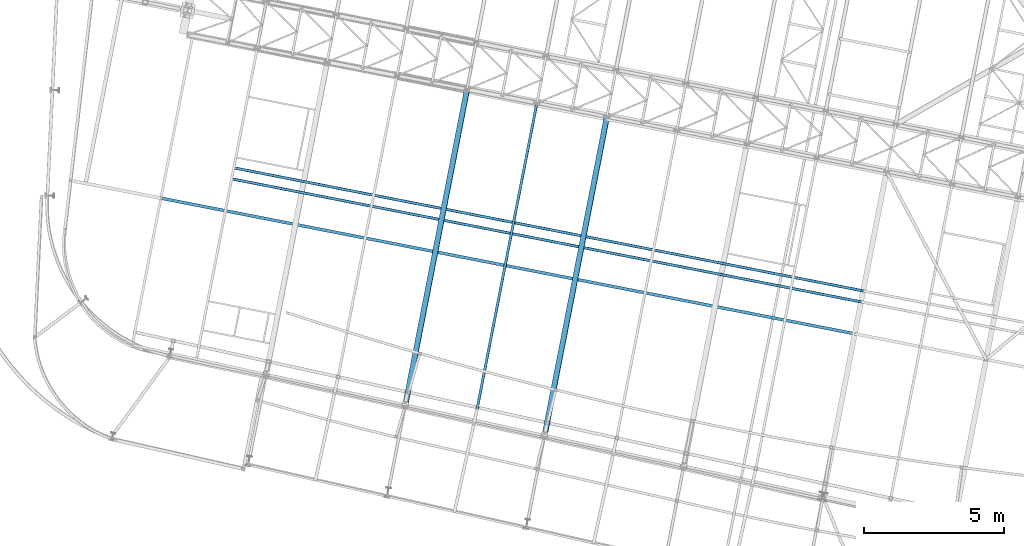
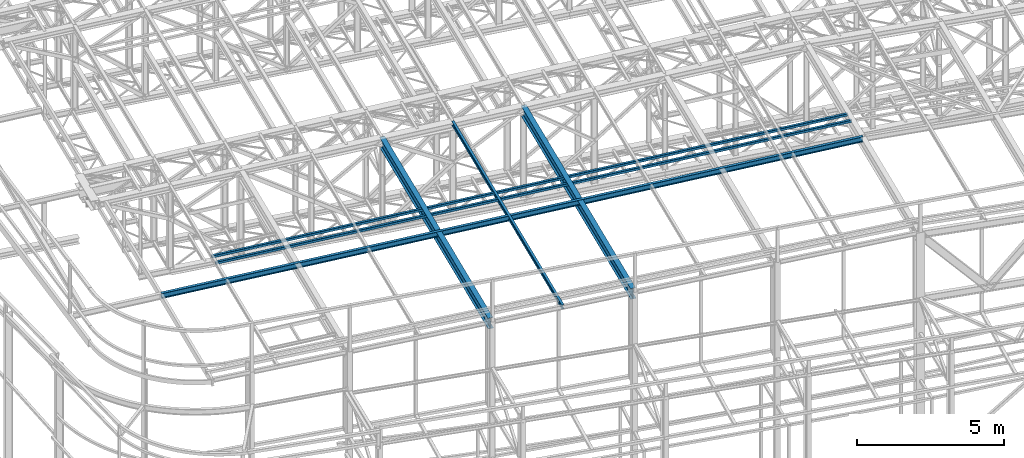
# One storey, part 36 of 215: 6 beams, 6 elements without a shape of their own.
"""IFC2X3 building model written with IfcOpenShell, lengths in millimetres."""

from ifc_helpers import new_model, si_unit, frame, origin_with_axes, origin_2d_with_axis, place, context, subcontext, project, spatial, hollow_rectangle, i_section, extrude, material, type_object, element, aggregate, save


model = new_model("IFC2X3")

# Units and contexts
model_context = context("Model", 3, precision=1e-05, world=origin_with_axes())
body_context = subcontext(model_context, "Body", "Model", "MODEL_VIEW")
ifc_project = project(units=[si_unit("LENGTHUNIT", "METRE", prefix="MILLI"), si_unit("AREAUNIT", "SQUARE_METRE"), si_unit("VOLUMEUNIT", "CUBIC_METRE"), si_unit("MASSUNIT", "GRAM", prefix="KILO"), si_unit("TIMEUNIT", "SECOND"), si_unit("PLANEANGLEUNIT", "RADIAN"), si_unit("SOLIDANGLEUNIT", "STERADIAN"), si_unit("THERMODYNAMICTEMPERATUREUNIT", "DEGREE_CELSIUS"), si_unit("LUMINOUSINTENSITYUNIT", "LUMEN")], contexts=[model_context])

# Site, building, storey
site_placement = place(None, origin_with_axes())
site = spatial("IfcSite", under=ifc_project, at=site_placement, CompositionType="ELEMENT")
building_placement = place(site_placement, origin_with_axes())
building = spatial("IfcBuilding", under=site, at=building_placement, Name="Undefined", CompositionType="ELEMENT")
storey_placement = place(building_placement, origin_with_axes())
storey = spatial("IfcBuildingStorey", under=building, at=storey_placement, Name="Undefined", CompositionType="ELEMENT", Elevation=0.0)

# Assembly, beam
assembly_1_placement = place(storey_placement, origin_with_axes())
assembly_1 = element("IfcElementAssembly", 1, at=assembly_1_placement, inside=storey, Name="Steel Assembly", AssemblyPlace="NOTDEFINED", PredefinedType="RIGID_FRAME")
ifc_material = material(Name="STEEL/S275JR")
beam_type_1 = type_object("IfcBeamType", PredefinedType="NOTDEFINED")
beam_1_placement = place(assembly_1_placement, frame((43900.8074871388, 17561.2137078709, 12080.2732554626), z_axis=(0.0304072880144601, -0.0059443590028274, -0.99951991547525), x_axis=(0.980943093982696, -0.191809039996616, 0.0309828749994535)))
beam_1 = element("IfcBeam", 2, at=beam_1_placement, type_object=beam_type_1, material=ifc_material, context=body_context, shape_type="SweptSolid", body=[
    extrude(hollow_rectangle(XDim=100.0, YDim=100.0, WallThickness=5.0, InnerFilletRadius=5.0, OuterFilletRadius=10.0, at=origin_2d_with_axis()), frame((22897.097980104, -8.21343149231186e-12, 3.71741907388737e-12), z_axis=(-1.0, 0.0, 0.0), x_axis=(-6.93889390390723e-18, -1.0, -3.46944695195361e-18)), (0.0, 0.0, 1.0), 22897.1),
])
aggregate(assembly_1, [beam_1])

assembly_2_placement = place(storey_placement, origin_with_axes())
assembly_2 = element("IfcElementAssembly", 3, at=assembly_2_placement, inside=storey, Name="Steel Assembly", AssemblyPlace="NOTDEFINED", PredefinedType="RIGID_FRAME")
beam_2_placement = place(assembly_2_placement, frame((43824.0469877255, 17168.6480118231, 12080.2732543694), z_axis=(0.0304072880144601, -0.0059443590028274, -0.99951991547525), x_axis=(0.980943093982696, -0.191809039996616, 0.0309828749994535)))
beam_2 = element("IfcBeam", 4, at=beam_2_placement, type_object=beam_type_1, material=ifc_material, context=body_context, shape_type="SweptSolid", body=[
    extrude(hollow_rectangle(XDim=100.0, YDim=100.0, WallThickness=5.0, InnerFilletRadius=5.0, OuterFilletRadius=10.0, at=origin_2d_with_axis()), frame((22896.595182409, -4.8084209346404e-14, 1.73955088118013e-12), z_axis=(-1.0, 0.0, 0.0), x_axis=(-6.93889390390723e-18, -1.0, -3.46944695195361e-18)), (0.0, 0.0, 1.0), 22896.6),
])
aggregate(assembly_2, [beam_2])

assembly_3_placement = place(storey_placement, origin_with_axes())
assembly_3 = element("IfcElementAssembly", 5, at=assembly_3_placement, inside=storey, Name="Steel Assembly", AssemblyPlace="NOTDEFINED", PredefinedType="RIGID_FRAME")
beam_type_2 = type_object("IfcBeamType", Name="IPE180", PredefinedType="NOTDEFINED")
beam_3_placement = place(assembly_3_placement, frame((52504.4399437992, 8549.24136425761, 12435.630963251), z_axis=(-0.0304080349967745, 0.00594450299936818, 0.999519891893966), x_axis=(0.191859470081235, 0.981422408415534, 0.0)))
beam_3 = element("IfcBeam", 6, at=beam_3_placement, type_object=beam_type_2, material=ifc_material, ObjectType="IPE180", context=body_context, shape_type="SweptSolid", body=[
    extrude(i_section(OverallWidth=91.0, OverallDepth=180.0, WebThickness=5.300000191, FlangeThickness=8.0, FilletRadius=9.0, at=origin_2d_with_axis()), frame((11539.9041034339, 2.97319904034928e-13, -1.81926197056477e-12), z_axis=(-1.0, 0.0, 0.0), x_axis=(-6.93889390390723e-18, -1.0, -3.46944695195361e-18)), (0.0, 0.0, 1.0), 11539.9),
])
aggregate(assembly_3, [beam_3])

assembly_4_placement = place(storey_placement, origin_with_axes())
assembly_4 = element("IfcElementAssembly", 7, at=assembly_4_placement, inside=storey, Name="Steel Assembly", AssemblyPlace="NOTDEFINED", PredefinedType="RIGID_FRAME")
beam_type_3 = type_object("IfcBeamType", Name="IPE220", PredefinedType="NOTDEFINED")
beam_4_placement = place(assembly_4_placement, frame((41298.9244745431, 16478.872607213, 12027.5595642054), z_axis=(-0.0304080349967745, 0.00594450299936818, 0.999519891893966), x_axis=(0.980951223231219, -0.191767338045201, 0.0309836360073031)))
beam_4 = element("IfcBeam", 8, at=beam_4_placement, type_object=beam_type_3, material=ifc_material, Name="POUTRE", ObjectType="IPE220", context=body_context, shape_type="SweptSolid", body=[
    extrude(i_section(OverallWidth=110.0, OverallDepth=220.0, WebThickness=5.900000095, FlangeThickness=9.199999809, FilletRadius=12.0, at=origin_2d_with_axis()), frame((25248.8431837588, -4.57601069335986e-12, 8.75995220242468e-14), z_axis=(-1.0, 0.0, 0.0), x_axis=(-6.93889390390723e-18, -1.0, -3.46944695195361e-18)), (0.0, 0.0, 1.0), 25248.8),
])
aggregate(assembly_4, [beam_4])

assembly_5_placement = place(storey_placement, origin_with_axes())
assembly_5 = element("IfcElementAssembly", 9, at=assembly_5_placement, inside=storey, Name="Steel Assembly", AssemblyPlace="NOTDEFINED", PredefinedType="RIGID_FRAME")
beam_type_4 = type_object("IfcBeamType", Name="IPE450", PredefinedType="NOTDEFINED")
beam_5_placement = place(assembly_5_placement, frame((52226.3587124326, 20361.9456832704, 12219.7593730283), z_axis=(-0.0304080349967745, 0.00594450299936818, 0.999519891893966), x_axis=(-0.191859508000518, -0.981422401002646, -1.00000033853845e-09)))
beam_5 = element("IfcBeam", 10, at=beam_5_placement, type_object=beam_type_4, material=ifc_material, Name="POUTRE", ObjectType="IPE450", context=body_context, shape_type="SweptSolid", body=[
    extrude(i_section(OverallWidth=190.0, OverallDepth=450.0, WebThickness=9.399999619, FlangeThickness=14.60000038, FilletRadius=21.0, at=origin_2d_with_axis()), frame((11365.8621601504, 7.45952513578043e-12, 6.74623173915535e-15), z_axis=(-1.0, 0.0, 0.0), x_axis=(-6.93889390390723e-18, -1.0, -3.46944695195361e-18)), (0.0, 0.0, 1.0), 11365.9),
])
aggregate(assembly_5, [beam_5])

assembly_6_placement = place(storey_placement, origin_with_axes())
assembly_6 = element("IfcElementAssembly", 11, at=assembly_6_placement, inside=storey, Name="Steel Assembly", AssemblyPlace="NOTDEFINED", PredefinedType="RIGID_FRAME")
beam_6_placement = place(assembly_6_placement, frame((57218.8069225202, 19385.9659577261, 12377.4473338926), z_axis=(-0.0304080349967745, 0.00594450299936818, 0.999519891893966), x_axis=(-0.191859508000518, -0.981422401002646, -1.00000033853845e-09)))
beam_6 = element("IfcBeam", 12, at=beam_6_placement, type_object=beam_type_4, material=ifc_material, Name="POUTRE", ObjectType="IPE450", context=body_context, shape_type="SweptSolid", body=[
    extrude(i_section(OverallWidth=190.0, OverallDepth=450.0, WebThickness=9.399999619, FlangeThickness=14.60000038, FilletRadius=21.0, at=origin_2d_with_axis()), frame((11483.9341747513, 7.47391350221701e-12, 1.10325772329717e-14), z_axis=(-1.0, 0.0, 0.0), x_axis=(-6.93889390390723e-18, -1.0, -3.46944695195361e-18)), (0.0, 0.0, 1.0), 11483.9),
])
aggregate(assembly_6, [beam_6])

save(model, "model.ifc")
